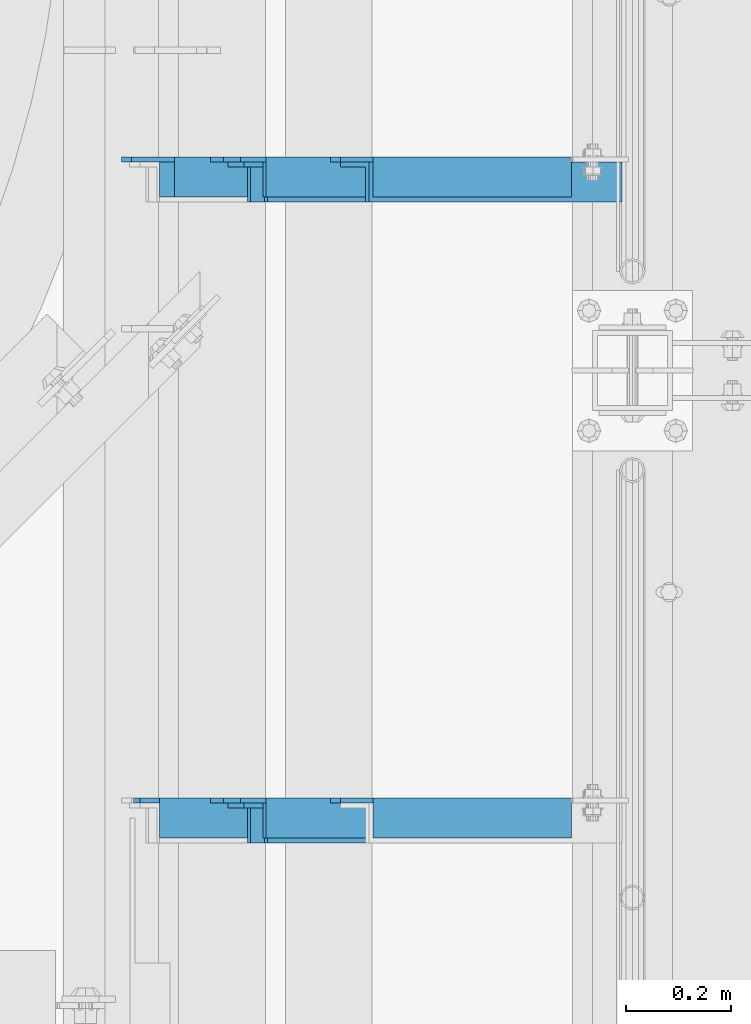
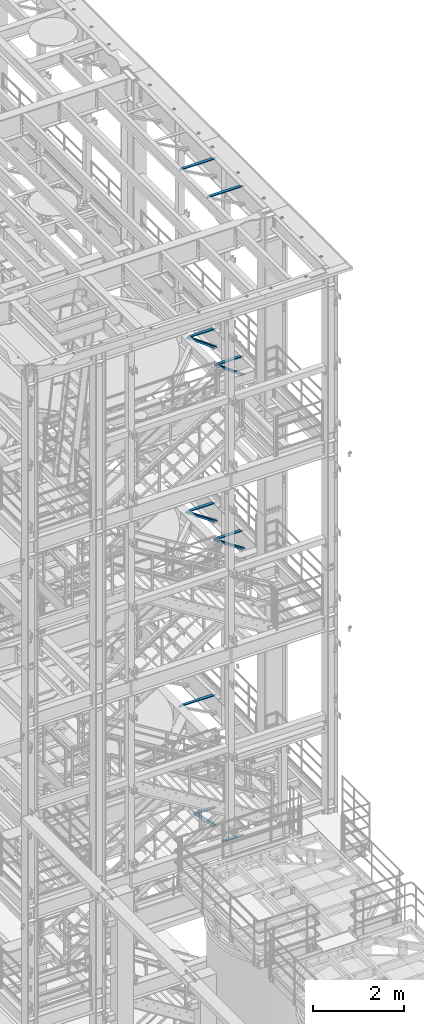
# One storey, part 1212 of 1876: 9 beams, 5 members, 14 elements without a shape of their own.
"""IFC2X3 building model written with IfcOpenShell, lengths in millimetres."""

from ifc_helpers import new_model, si_unit, frame, origin_with_axes, place, context, subcontext, project, spatial, faceted_brep, material, type_object, element, aggregate, save


model = new_model("IFC2X3")

# Units and contexts
model_context = context("Model", 3, precision=1e-05, world=origin_with_axes())
body_context = subcontext(model_context, "Body", "Model", "MODEL_VIEW")
ifc_project = project(units=[si_unit("LENGTHUNIT", "METRE", prefix="MILLI"), si_unit("AREAUNIT", "SQUARE_METRE"), si_unit("VOLUMEUNIT", "CUBIC_METRE"), si_unit("MASSUNIT", "GRAM", prefix="KILO"), si_unit("TIMEUNIT", "SECOND"), si_unit("PLANEANGLEUNIT", "RADIAN"), si_unit("SOLIDANGLEUNIT", "STERADIAN"), si_unit("THERMODYNAMICTEMPERATUREUNIT", "DEGREE_CELSIUS"), si_unit("LUMINOUSINTENSITYUNIT", "LUMEN")], contexts=[model_context])

# Site, building, storey
site_placement = place(None, origin_with_axes())
site = spatial("IfcSite", under=ifc_project, at=site_placement, CompositionType="ELEMENT")
building_placement = place(site_placement, origin_with_axes())
building = spatial("IfcBuilding", under=site, at=building_placement, Name="Undefined", CompositionType="ELEMENT")
storey_placement = place(building_placement, origin_with_axes())
storey = spatial("IfcBuildingStorey", under=building, at=storey_placement, Name="Undefined", CompositionType="ELEMENT", Elevation=0.0)

# Assembly, member
assembly_1_placement = place(storey_placement, origin_with_axes())
assembly_1 = element("IfcElementAssembly", 1, at=assembly_1_placement, inside=storey, AssemblyPlace="NOTDEFINED", PredefinedType="RIGID_FRAME")
ifc_material = material(Name="STEEL/A36")
member_type = type_object("IfcMemberType", Name="L3X3X3/8", PredefinedType="NOTDEFINED")
member_1_placement = place(assembly_1_placement, frame((7040.82073558349, -2181.225, 5132.08684596299), z_axis=(0.0, -1.0, 0.0), x_axis=(0.701378051870177, 0.0, -0.712789469868064)))
member_1 = element("IfcMember", 2, at=member_1_placement, type_object=member_type, material=ifc_material, ObjectType="L3X3X3/8", context=body_context, shape_type="Brep", body=[
    faceted_brep([(758.761261852226, 28.5750000000353, 38.0999999999999), (758.761261852226, 28.5750000000353, -28.5749999999998), (758.761261852226, -38.0999999999494, -28.5749999999998), (758.761261852226, -38.0999999999494, -38.0999999999999), (758.761261852226, 38.1000000000313, -38.0999999999999), (758.761261852226, 38.1000000000313, 38.0999999999999), (72.7035731357846, 28.5749999999971, 38.0999999999999), (72.7035731357846, 28.5749999999971, -28.5749999999998), (72.7035731357837, -38.0999999999876, -28.5749999999998), (72.7035731357837, -38.0999999999876, -38.0999999999999), (72.7035731357851, 38.0999999999949, -38.0999999999999), (72.7035731357851, 38.0999999999949, 38.0999999999999)], [[[0, 1, 2, 3, 4, 5]], [[1, 0, 6, 7]], [[2, 1, 7, 8]], [[3, 2, 8, 9]], [[4, 3, 9, 10]], [[5, 4, 10, 11]], [[0, 5, 11, 6]], [[10, 9, 8, 7, 6, 11]]]),
])
aggregate(assembly_1, [member_1])

assembly_2_placement = place(storey_placement, origin_with_axes())
assembly_2 = element("IfcElementAssembly", 3, at=assembly_2_placement, inside=storey, Name="BRACE", AssemblyPlace="NOTDEFINED", PredefinedType="RIGID_FRAME")
member_2_placement = place(assembly_2_placement, frame((6792.18717854473, -3400.425, 13303.4525776102), z_axis=(0.0, -1.0, 0.0), x_axis=(0.82801633589084, 0.0, -0.560703974926081)))
member_2 = element("IfcMember", 4, at=member_2_placement, type_object=member_type, material=ifc_material, Name="BRACE", ObjectType="L3X3X3/8", context=body_context, shape_type="Brep", body=[
    faceted_brep([(96.2629166569975, 38.0999999999149, -38.0999999999999), (96.2629166569975, 38.0999999999149, 38.0999999999999), (949.988805673232, 38.0999999993637, 38.0999999999999), (949.988805673232, 38.0999999993637, -38.0999999999999), (96.2629166570039, 28.5749999999189, 38.0999999999999), (949.98880567324, 28.5749999993659, 38.0999999999999), (96.2629166570039, 28.5749999999189, -28.5749999999998), (949.98880567324, 28.5749999993659, -28.5749999999998), (96.2629166570548, -38.1000000000404, -28.5749999999998), (949.98880567329, -38.1000000005952, -28.5749999999998), (96.2629166570548, -38.1000000000404, -38.0999999999999), (949.98880567329, -38.1000000005952, -38.0999999999999)], [[[0, 1, 2, 3]], [[1, 4, 5, 2]], [[4, 6, 7, 5]], [[6, 8, 9, 7]], [[8, 10, 11, 9]], [[10, 0, 3, 11]], [[5, 7, 9, 11, 3, 2]], [[10, 8, 6, 4, 1, 0]]]),
])
aggregate(assembly_2, [member_2])

assembly_3_placement = place(storey_placement, origin_with_axes())
assembly_3 = element("IfcElementAssembly", 5, at=assembly_3_placement, inside=storey, Name="BRACE", AssemblyPlace="NOTDEFINED", PredefinedType="RIGID_FRAME")
member_3_placement = place(assembly_3_placement, frame((6792.18717854473, -2181.225, 13303.4525776102), z_axis=(0.0, -1.0, 0.0), x_axis=(0.82801633589084, 0.0, -0.560703974926081)))
member_3 = element("IfcMember", 6, at=member_3_placement, type_object=member_type, material=ifc_material, Name="BRACE", ObjectType="L3X3X3/8", context=body_context, shape_type="Brep", body=[
    faceted_brep([(96.2629166569975, 38.0999999999149, -38.0999999999999), (96.2629166569975, 38.0999999999149, 38.0999999999999), (949.988805673232, 38.0999999993637, 38.0999999999999), (949.988805673232, 38.0999999993637, -38.0999999999999), (96.2629166570039, 28.5749999999189, 38.0999999999999), (949.98880567324, 28.5749999993659, 38.0999999999999), (96.2629166570039, 28.5749999999189, -28.5749999999998), (949.98880567324, 28.5749999993659, -28.5749999999998), (96.2629166570548, -38.1000000000404, -28.5749999999998), (949.98880567329, -38.1000000005952, -28.5749999999998), (96.2629166570548, -38.1000000000404, -38.0999999999999), (949.98880567329, -38.1000000005952, -38.0999999999999)], [[[0, 1, 2, 3]], [[1, 4, 5, 2]], [[4, 6, 7, 5]], [[6, 8, 9, 7]], [[8, 10, 11, 9]], [[10, 0, 3, 11]], [[5, 7, 9, 11, 3, 2]], [[10, 8, 6, 4, 1, 0]]]),
])
aggregate(assembly_3, [member_3])

assembly_4_placement = place(storey_placement, origin_with_axes())
assembly_4 = element("IfcElementAssembly", 7, at=assembly_4_placement, inside=storey, AssemblyPlace="NOTDEFINED", PredefinedType="RIGID_FRAME")
member_4_placement = place(assembly_4_placement, frame((6816.45156900301, -3400.425, 17993.727144592), z_axis=(0.0, -1.0, 0.0), x_axis=(0.807030325960616, 0.0, -0.590509993971229)))
member_4 = element("IfcMember", 8, at=member_4_placement, type_object=member_type, material=ifc_material, ObjectType="L3X3X3/8", context=body_context, shape_type="Brep", body=[
    faceted_brep([(107.534166499222, 38.1000000000786, -38.0999999999999), (107.534166499222, 38.1000000000786, 38.0999999999999), (943.218892448816, 38.1000000010463, 38.0999999999999), (943.218892448816, 38.1000000010463, -38.0999999999999), (107.534166499204, 28.5750000000917, 38.0999999999999), (943.2188924488, 28.5750000010594, 38.0999999999999), (107.534166499204, 28.5750000000917, -28.5749999999998), (943.2188924488, 28.5750000010594, -28.5749999999998), (107.534166499082, -38.0999999998239, -28.5749999999998), (943.218892448681, -38.0999999988562, -28.5749999999998), (107.534166499082, -38.0999999998239, -38.0999999999999), (943.218892448681, -38.0999999988562, -38.0999999999999)], [[[0, 1, 2, 3]], [[1, 4, 5, 2]], [[4, 6, 7, 5]], [[6, 8, 9, 7]], [[8, 10, 11, 9]], [[10, 0, 3, 11]], [[5, 7, 9, 11, 3, 2]], [[10, 8, 6, 4, 1, 0]]]),
])
aggregate(assembly_4, [member_4])

assembly_5_placement = place(storey_placement, origin_with_axes())
assembly_5 = element("IfcElementAssembly", 9, at=assembly_5_placement, inside=storey, AssemblyPlace="NOTDEFINED", PredefinedType="RIGID_FRAME")
member_5_placement = place(assembly_5_placement, frame((6816.45156900301, -2181.225, 17993.727144592), z_axis=(0.0, -1.0, 0.0), x_axis=(0.807030325960616, 0.0, -0.590509993971229)))
member_5 = element("IfcMember", 10, at=member_5_placement, type_object=member_type, material=ifc_material, ObjectType="L3X3X3/8", context=body_context, shape_type="Brep", body=[
    faceted_brep([(107.534166499222, 38.1000000000786, -38.0999999999999), (107.534166499222, 38.1000000000786, 38.0999999999999), (943.218892448816, 38.1000000010463, 38.0999999999999), (943.218892448816, 38.1000000010463, -38.0999999999999), (107.534166499204, 28.5750000000917, 38.0999999999999), (943.2188924488, 28.5750000010594, 38.0999999999999), (107.534166499204, 28.5750000000917, -28.5749999999998), (943.2188924488, 28.5750000010594, -28.5749999999998), (107.534166499082, -38.0999999998239, -28.5749999999998), (943.218892448681, -38.0999999988562, -28.5749999999998), (107.534166499082, -38.0999999998239, -38.0999999999999), (943.218892448681, -38.0999999988562, -38.0999999999999)], [[[0, 1, 2, 3]], [[1, 4, 5, 2]], [[4, 6, 7, 5]], [[6, 8, 9, 7]], [[8, 10, 11, 9]], [[10, 0, 3, 11]], [[5, 7, 9, 11, 3, 2]], [[10, 8, 6, 4, 1, 0]]]),
])
aggregate(assembly_5, [member_5])

# Assembly, beam
assembly_6_placement = place(storey_placement, origin_with_axes())
assembly_6 = element("IfcElementAssembly", 11, at=assembly_6_placement, inside=storey, Name="ANGLE", AssemblyPlace="NOTDEFINED", PredefinedType="RIGID_FRAME")
beam_type = type_object("IfcBeamType", Name="L3X3X3/8", PredefinedType="NOTDEFINED")
beam_1_placement = place(assembly_6_placement, frame((6642.10000000027, -2171.7, 8115.3), z_axis=(0.0, -1.0, 0.0), x_axis=(1.0, 0.0, 0.0)))
beam_1 = element("IfcBeam", 12, at=beam_1_placement, type_object=beam_type, material=ifc_material, Name="ANGLE", ObjectType="L3X3X3/8", context=body_context, shape_type="Brep", body=[
    faceted_brep([(862.013000301767, 28.5749999999998, -28.5749999999998), (862.013001168541, 28.5749999999998, 38.0999999999999), (106.361999785874, 28.5749999999998, 38.0999999999999), (106.361998852422, 28.5749999999998, -28.5749999999998), (862.013001168541, 38.1000000000004, 38.0999999999999), (106.36199978587, 38.1000000000004, 38.0999999999999), (24.6062501036349, 20.6380008697515, -28.5749999999998), (24.6062499702866, 20.6380008697515, -38.0999999999999), (5.55625073322608, 1.58800163269098, -38.0999999999999), (5.55625086657437, 1.58800163269098, -28.5749999999998), (106.361998852423, 20.6380008697515, -28.5749999999998), (106.361998719075, 20.6380008697515, -38.0999999999999), (106.361998719068, 38.1000000000004, -38.0999999999999), (862.013000177942, 38.1000000000004, -38.0999999999999), (862.013000301742, 12.6999992370602, -28.5749999999998), (862.013000177913, 12.6999992370602, -38.0999999999999), (939.006248287582, 12.6999992370602, -28.5749999999998), (939.006248163753, 12.6999992370602, -38.0999999999999), (970.756248287582, -19.0500007629398, -28.5749999999998), (970.756248163753, -19.0500007629398, -38.0999999999999), (970.75624999973, -38.1000000000004, -28.5749999999998), (970.75624999973, -38.1000000000004, -38.0999999999999), (5.55625000000055, -38.1000000000004, -28.5749999999998), (5.55625000000055, -38.1000000000004, -38.1000000000004), (5.55625073322608, -4.76199874877875, -38.0999999999999), (5.55625086657437, -4.76199874877875, -28.5749999999998)], [[[0, 1, 2, 3]], [[1, 4, 5, 2]], [[6, 7, 8, 9]], [[10, 11, 7, 6]], [[2, 5, 12, 11, 10, 3]], [[4, 13, 12, 5]], [[1, 0, 14, 15, 13, 4]], [[16, 17, 15, 14]], [[17, 16, 18, 19]], [[19, 18, 20, 21]], [[21, 20, 22, 23]], [[8, 7, 11, 12, 13, 15, 17, 19, 21, 23, 24]], [[9, 8, 24, 25]], [[20, 18, 16, 14, 0, 3, 10, 6, 9, 25, 22]], [[24, 23, 22, 25]]]),
])
aggregate(assembly_6, [beam_1])

assembly_7_placement = place(storey_placement, origin_with_axes())
assembly_7 = element("IfcElementAssembly", 13, at=assembly_7_placement, inside=storey, Name="ANGLE", AssemblyPlace="NOTDEFINED", PredefinedType="RIGID_FRAME")
beam_2_placement = place(assembly_7_placement, frame((6667.50000000095, -3390.9, 22517.1000001129), z_axis=(0.0, -1.0, 0.0), x_axis=(1.0, 0.0, 0.0)))
beam_2 = element("IfcBeam", 14, at=beam_2_placement, type_object=beam_type, material=ifc_material, Name="ANGLE", ObjectType="L3X3X3/8", context=body_context, shape_type="Brep", body=[
    faceted_brep([(836.613000301995, 28.5750000000007, -28.5749999999998), (836.613001168791, 28.5750000000007, 38.0999999999999), (52.3870335430847, 28.5750001907327, 38.0999999999858), (52.3869956588824, 28.5749999999955, -28.5750000000007), (836.613001168791, 38.0999999999985, 38.0999999999999), (52.387033543122, 38.0999999999985, 38.0999999999858), (15.8749936676099, 28.5749999999989, -28.5750000000007), (15.8749999382144, 28.5750001907327, -38.0999999999999), (3.17500012894925, 15.8750003814675, -38.0999999999999), (3.17500032897624, 15.8750003814675, -28.5749999999998), (52.3870393343063, 28.5750001907327, -38.1000000000149), (52.3869953826566, 38.0999999999954, -38.0999999999985), (836.613000178167, 38.0999999999985, -38.0999999999999), (836.613000301995, 12.6999991241828, -28.5749999999998), (836.613000178167, 12.6999991241828, -38.0999999999999), (913.60625591723, 12.6999991241828, -28.5749999999998), (913.606255793401, 12.6999991241828, -38.0999999999999), (945.35625591723, -19.0500008758172, -28.5749999999998), (945.356255793401, -19.0500008758172, -38.0999999999999), (945.356249999983, -38.0999999999985, -28.5749999999998), (945.356249999983, -38.0999999999985, -38.0999999999999), (3.17499999075153, -38.0999999999985, -28.5749999999998), (3.17499999075153, -38.0999999999985, -38.0999999999999), (3.17500012894925, 3.17500152587672, -38.0999999999999), (3.17500032897624, 3.17500152587672, -28.5749999999998)], [[[0, 1, 2, 3]], [[1, 4, 5, 2]], [[6, 7, 8, 9]], [[3, 10, 7, 6]], [[2, 5, 11, 10, 3]], [[4, 12, 11, 5]], [[1, 0, 13, 14, 12, 4]], [[15, 16, 14, 13]], [[16, 15, 17, 18]], [[18, 17, 19, 20]], [[20, 19, 21, 22]], [[8, 7, 10, 11, 12, 14, 16, 18, 20, 22, 23]], [[9, 8, 23, 24]], [[19, 17, 15, 13, 0, 3, 6, 9, 24, 21]], [[23, 22, 21, 24]]]),
])
aggregate(assembly_7, [beam_2])

assembly_8_placement = place(storey_placement, origin_with_axes())
assembly_8 = element("IfcElementAssembly", 15, at=assembly_8_placement, inside=storey, Name="ANGLE", AssemblyPlace="NOTDEFINED", PredefinedType="RIGID_FRAME")
beam_3_placement = place(assembly_8_placement, frame((6667.50000000095, -2171.7, 22517.1000001129), z_axis=(0.0, -1.0, 0.0), x_axis=(1.0, 0.0, 0.0)))
beam_3 = element("IfcBeam", 16, at=beam_3_placement, type_object=beam_type, material=ifc_material, Name="ANGLE", ObjectType="L3X3X3/8", context=body_context, shape_type="Brep", body=[
    faceted_brep([(836.613000301995, 28.5750000000007, -28.5749999999998), (836.613001168791, 28.5750000000007, 38.0999999999999), (52.3870335430847, 28.5750001907327, 38.0999999999858), (52.3869956588824, 28.5749999999955, -28.5750000000007), (836.613001168791, 38.0999999999985, 38.0999999999999), (52.387033543122, 38.0999999999985, 38.0999999999858), (15.8749936676099, 28.5749999999989, -28.5750000000007), (15.8749999382144, 28.5750001907327, -38.0999999999999), (3.17500012894925, 15.8750003814675, -38.0999999999999), (3.17500032897624, 15.8750003814675, -28.5749999999998), (52.3870393343063, 28.5750001907327, -38.1000000000149), (52.3869953826566, 38.0999999999954, -38.0999999999985), (836.613000178167, 38.0999999999985, -38.0999999999999), (836.613000301995, 12.6999991241828, -28.5749999999998), (836.613000178167, 12.6999991241828, -38.0999999999999), (913.60625591723, 12.6999991241828, -28.5749999999998), (913.606255793401, 12.6999991241828, -38.0999999999999), (945.35625591723, -19.0500008758172, -28.5749999999998), (945.356255793401, -19.0500008758172, -38.0999999999999), (945.356249999983, -38.0999999999985, -28.5749999999998), (945.356249999983, -38.0999999999985, -38.0999999999999), (3.17499999075153, -38.0999999999985, -28.5749999999998), (3.17499999075153, -38.0999999999985, -38.0999999999999), (3.17500012894925, 3.17500152587672, -38.0999999999999), (3.17500032897624, 3.17500152587672, -28.5749999999998)], [[[0, 1, 2, 3]], [[1, 4, 5, 2]], [[6, 7, 8, 9]], [[3, 10, 7, 6]], [[2, 5, 11, 10, 3]], [[4, 12, 11, 5]], [[1, 0, 13, 14, 12, 4]], [[15, 16, 14, 13]], [[16, 15, 17, 18]], [[18, 17, 19, 20]], [[20, 19, 21, 22]], [[8, 7, 10, 11, 12, 14, 16, 18, 20, 22, 23]], [[9, 8, 23, 24]], [[19, 17, 15, 13, 0, 3, 6, 9, 24, 21]], [[23, 22, 21, 24]]]),
])
aggregate(assembly_8, [beam_3])

assembly_9_placement = place(storey_placement, origin_with_axes())
assembly_9 = element("IfcElementAssembly", 17, at=assembly_9_placement, inside=storey, Name="ANGLE", AssemblyPlace="NOTDEFINED", PredefinedType="RIGID_FRAME")
beam_4_placement = place(assembly_9_placement, frame((6838.94981327725, -3390.9, 17945.1), z_axis=(0.0, -1.0, 0.0), x_axis=(1.0, 0.0, 0.0)))
beam_4 = element("IfcBeam", 18, at=beam_4_placement, type_object=beam_type, material=ifc_material, Name="ANGLE", ObjectType="L3X3X3/8", context=body_context, shape_type="Brep", body=[
    faceted_brep([(665.163187024773, 28.5750000000007, -28.5749999999998), (665.163187891547, 28.5750000000007, 38.0999999999999), (84.137014014791, 28.5749999999998, 38.1000000000258), (84.1370001605219, 28.5749999999998, -28.5750000000007), (665.163187891547, 38.0999999999985, 38.0999999999999), (84.136999759924, 38.0999999999985, 38.0999999999999), (84.1369986264499, 22.2250007629373, -28.5749999999998), (84.1369984645216, 22.2250007629373, -38.0999999999999), (34.9250004786818, 22.2250007629373, -38.0999999999999), (34.9250006406101, 22.2250007629373, -28.5749999999998), (84.1369984645207, 38.0999999999985, -38.0999999999999), (665.163186900948, 38.0999999999985, -38.0999999999999), (665.163187024748, 12.6999992370475, -28.5749999999998), (665.16318690092, 12.6999992370475, -38.0999999999999), (742.156442639983, 12.6999992370475, -28.5749999999998), (742.156442516154, 12.6999992370475, -38.0999999999999), (773.906442639983, -19.0500007629525, -28.5749999999998), (773.906442516154, -19.0500007629525, -38.0999999999999), (773.906436722751, -38.0999999999985, -28.5749999999998), (773.906436722751, -38.0999999999985, -38.0999999999999), (3.17499999075153, -38.0999999999985, -28.5749999999998), (3.17499999075153, -38.0999999999985, -38.0999999999999), (3.1750004786818, -9.52499923706273, -38.0999999999999), (3.17500064061005, -9.52499923706273, -28.5749999999998)], [[[0, 1, 2, 3]], [[1, 4, 5, 2]], [[6, 7, 8, 9]], [[2, 5, 10, 7, 6, 3]], [[4, 11, 10, 5]], [[1, 0, 12, 13, 11, 4]], [[14, 15, 13, 12]], [[15, 14, 16, 17]], [[17, 16, 18, 19]], [[19, 18, 20, 21]], [[8, 7, 10, 11, 13, 15, 17, 19, 21, 22]], [[9, 8, 22, 23]], [[18, 16, 14, 12, 0, 3, 6, 9, 23, 20]], [[22, 21, 20, 23]]]),
])
aggregate(assembly_9, [beam_4])

assembly_10_placement = place(storey_placement, origin_with_axes())
assembly_10 = element("IfcElementAssembly", 19, at=assembly_10_placement, inside=storey, Name="ANGLE", AssemblyPlace="NOTDEFINED", PredefinedType="RIGID_FRAME")
beam_5_placement = place(assembly_10_placement, frame((6838.94981327725, -2171.7, 17945.1), z_axis=(0.0, -1.0, 0.0), x_axis=(1.0, 0.0, 0.0)))
beam_5 = element("IfcBeam", 20, at=beam_5_placement, type_object=beam_type, material=ifc_material, Name="ANGLE", ObjectType="L3X3X3/8", context=body_context, shape_type="Brep", body=[
    faceted_brep([(665.163187024773, 28.5750000000007, -28.5749999999998), (665.163187891547, 28.5750000000007, 38.0999999999999), (84.137014014791, 28.5749999999998, 38.1000000000258), (84.1370001605219, 28.5749999999998, -28.5750000000007), (665.163187891547, 38.0999999999985, 38.0999999999999), (84.136999759924, 38.0999999999985, 38.0999999999999), (84.1369986264499, 22.2250007629373, -28.5749999999998), (84.1369984645216, 22.2250007629373, -38.0999999999999), (34.9250004786818, 22.2250007629373, -38.0999999999999), (34.9250006406101, 22.2250007629373, -28.5749999999998), (84.1369984645207, 38.0999999999985, -38.0999999999999), (665.163186900948, 38.0999999999985, -38.0999999999999), (665.163187024748, 12.6999992370475, -28.5749999999998), (665.16318690092, 12.6999992370475, -38.0999999999999), (742.156442639983, 12.6999992370475, -28.5749999999998), (742.156442516154, 12.6999992370475, -38.0999999999999), (773.906442639983, -19.0500007629525, -28.5749999999998), (773.906442516154, -19.0500007629525, -38.0999999999999), (773.906436722751, -38.0999999999985, -28.5749999999998), (773.906436722751, -38.0999999999985, -38.0999999999999), (3.17499999075153, -38.0999999999985, -28.5749999999998), (3.17499999075153, -38.0999999999985, -38.0999999999999), (3.1750004786818, -9.52499923706273, -38.0999999999999), (3.17500064061005, -9.52499923706273, -28.5749999999998)], [[[0, 1, 2, 3]], [[1, 4, 5, 2]], [[6, 7, 8, 9]], [[2, 5, 10, 7, 6, 3]], [[4, 11, 10, 5]], [[1, 0, 12, 13, 11, 4]], [[14, 15, 13, 12]], [[15, 14, 16, 17]], [[17, 16, 18, 19]], [[19, 18, 20, 21]], [[8, 7, 10, 11, 13, 15, 17, 19, 21, 22]], [[9, 8, 22, 23]], [[18, 16, 14, 12, 0, 3, 6, 9, 23, 20]], [[22, 21, 20, 23]]]),
])
aggregate(assembly_10, [beam_5])

assembly_11_placement = place(storey_placement, origin_with_axes())
assembly_11 = element("IfcElementAssembly", 21, at=assembly_11_placement, inside=storey, Name="ANGLE", AssemblyPlace="NOTDEFINED", PredefinedType="RIGID_FRAME")
beam_6_placement = place(assembly_11_placement, frame((7042.15, -3390.9, 5092.7), z_axis=(0.0, -1.0, 0.0), x_axis=(1.0, 0.0, 0.0)))
beam_6 = element("IfcBeam", 22, at=beam_6_placement, type_object=beam_type, material=ifc_material, Name="ANGLE", ObjectType="L3X3X3/8", context=body_context, shape_type="Brep", body=[
    faceted_brep([(461.963000256203, 28.5750000000007, -28.5749999999998), (461.963001056292, 28.5750000000007, 38.0999999999999), (84.1370686928021, 28.5750001907327, 38.100000000024), (84.1370606917826, 28.5750000000007, -28.5749999999771), (461.963001056292, 38.1000000000004, 38.0999999999999), (84.1374011325761, 38.0999999999985, 38.0999999999776), (22.2249552881549, 26.9870083863452, -28.5749999999935), (22.2249551643299, 26.9870094055232, -38.0999999999931), (3.17495592726937, 7.93701016846171, -38.0999999999995), (3.17495605109434, 7.93700914928468, -28.5749999999989), (84.1369575769495, 26.9870083863452, -28.5749999999744), (84.1369574531245, 26.9870094055223, -38.099999999974), (84.137408980816, 38.0999999999985, -38.1000000000231), (461.963000141903, 38.1000000000004, -38.0999999999999), (461.963000302011, 12.6999992370611, -28.5749999999998), (461.963000178182, 12.6999992370611, -38.0999999999999), (538.956248287851, 12.6999992370611, -28.5749999999998), (538.956248164022, 12.6999992370611, -38.0999999999999), (570.706248287851, -19.0500007629389, -28.5749999999998), (570.706248164022, -19.0500007629389, -38.0999999999999), (570.706249999999, -38.1000000000004, -28.5749999999998), (570.706249999999, -38.1000000000004, -38.0999999999999), (3.17499999075153, -38.0999999999985, -28.5749999999998), (3.17499999075153, -38.0999999999985, -38.0999999999999), (3.17495592726937, 1.58700978699198, -38.0999999999995), (3.17495605109434, 1.58700876781495, -28.5749999999989)], [[[0, 1, 2, 3]], [[1, 4, 5, 2]], [[6, 7, 8, 9]], [[10, 11, 7, 6]], [[2, 5, 12, 11, 10, 3]], [[4, 13, 12, 5]], [[1, 0, 14, 15, 13, 4]], [[16, 17, 15, 14]], [[17, 16, 18, 19]], [[19, 18, 20, 21]], [[21, 20, 22, 23]], [[8, 7, 11, 12, 13, 15, 17, 19, 21, 23, 24]], [[9, 8, 24, 25]], [[20, 18, 16, 14, 0, 3, 10, 6, 9, 25, 22]], [[24, 23, 22, 25]]]),
])
aggregate(assembly_11, [beam_6])

assembly_12_placement = place(storey_placement, origin_with_axes())
assembly_12 = element("IfcElementAssembly", 23, at=assembly_12_placement, inside=storey, Name="ANGLE", AssemblyPlace="NOTDEFINED", PredefinedType="RIGID_FRAME")
beam_7_placement = place(assembly_12_placement, frame((7042.15, -2171.7, 5092.7), z_axis=(0.0, -1.0, 0.0), x_axis=(1.0, 0.0, 0.0)))
beam_7 = element("IfcBeam", 24, at=beam_7_placement, type_object=beam_type, material=ifc_material, Name="ANGLE", ObjectType="L3X3X3/8", context=body_context, shape_type="Brep", body=[
    faceted_brep([(461.963000256203, 28.5750000000007, -28.5749999999998), (461.963001056292, 28.5750000000007, 38.0999999999999), (84.1370686928021, 28.5750001907327, 38.100000000024), (84.1370606917826, 28.5750000000007, -28.5749999999771), (461.963001056292, 38.1000000000004, 38.0999999999999), (84.1374011325761, 38.0999999999985, 38.0999999999776), (22.2249552881549, 26.9870083863452, -28.5749999999935), (22.2249551643299, 26.9870094055232, -38.0999999999931), (3.17495592726937, 7.93701016846171, -38.0999999999995), (3.17495605109434, 7.93700914928468, -28.5749999999989), (84.1369575769495, 26.9870083863452, -28.5749999999744), (84.1369574531245, 26.9870094055223, -38.099999999974), (84.137408980816, 38.0999999999985, -38.1000000000231), (461.963000141903, 38.1000000000004, -38.0999999999999), (461.963000302011, 12.6999992370611, -28.5749999999998), (461.963000178182, 12.6999992370611, -38.0999999999999), (538.956248287851, 12.6999992370611, -28.5749999999998), (538.956248164022, 12.6999992370611, -38.0999999999999), (570.706248287851, -19.0500007629389, -28.5749999999998), (570.706248164022, -19.0500007629389, -38.0999999999999), (570.706249999999, -38.1000000000004, -28.5749999999998), (570.706249999999, -38.1000000000004, -38.0999999999999), (3.17499999075153, -38.0999999999985, -28.5749999999998), (3.17499999075153, -38.0999999999985, -38.0999999999999), (3.17495592726937, 1.58700978699198, -38.0999999999995), (3.17495605109434, 1.58700876781495, -28.5749999999989)], [[[0, 1, 2, 3]], [[1, 4, 5, 2]], [[6, 7, 8, 9]], [[10, 11, 7, 6]], [[2, 5, 12, 11, 10, 3]], [[4, 13, 12, 5]], [[1, 0, 14, 15, 13, 4]], [[16, 17, 15, 14]], [[17, 16, 18, 19]], [[19, 18, 20, 21]], [[21, 20, 22, 23]], [[8, 7, 11, 12, 13, 15, 17, 19, 21, 23, 24]], [[9, 8, 24, 25]], [[20, 18, 16, 14, 0, 3, 10, 6, 9, 25, 22]], [[24, 23, 22, 25]]]),
])
aggregate(assembly_12, [beam_7])

assembly_13_placement = place(storey_placement, origin_with_axes())
assembly_13 = element("IfcElementAssembly", 25, at=assembly_13_placement, inside=storey, Name="ANGLE", AssemblyPlace="NOTDEFINED", PredefinedType="RIGID_FRAME")
beam_8_placement = place(assembly_13_placement, frame((6813.54999999292, -3390.9, 13271.4999999928), z_axis=(0.0, -1.0, 0.0), x_axis=(1.0, 0.0, 0.0)))
beam_8 = element("IfcBeam", 26, at=beam_8_placement, type_object=beam_type, material=ifc_material, Name="ANGLE", ObjectType="L3X3X3/8", context=body_context, shape_type="Brep", body=[
    faceted_brep([(690.56300030954, 28.5750000000007, -28.5749999999998), (690.563001176313, 28.5750000000007, 38.0999999999999), (103.186999799132, 28.5750000000007, 38.0999999999999), (103.186998865692, 28.5750000000007, -28.5749999999998), (690.563001175733, 38.1000000000004, 38.0999999999999), (103.186999799132, 38.1000000000004, 38.0999999999999), (103.186998865692, 22.2250007629391, -28.5749999999998), (103.186998732343, 22.2250007629391, -38.0999999999999), (29.3687518909128, 22.2250007629391, -38.0999999999999), (29.3687520242611, 22.2250007629391, -28.5749999999998), (103.186998732343, 38.1000000000004, -38.0999999999999), (690.563000185135, 38.1000000000004, -38.0999999999999), (690.563000310482, 12.6999992442816, -28.5749999999998), (690.563000186654, 12.6999992442816, -38.0999999999999), (767.556248294582, 12.6999992442816, -28.5749999999998), (767.556248170753, 12.6999992442816, -38.0999999999999), (799.306248294582, -19.0500007557184, -28.5749999999998), (799.306248170753, -19.0500007557184, -38.0999999999999), (799.30625000673, -38.1000000000004, -28.5749999999998), (799.30625000673, -38.1000000000004, -38.0999999999999), (3.96875000000273, -38.1000000000004, -28.5749999999998), (3.96875000000273, -38.1000000000004, -38.0999999999999), (3.96875227238252, -3.17500076293982, -38.0999999999999), (3.96875240573081, -3.17500076293982, -28.5749999999998)], [[[0, 1, 2, 3]], [[1, 4, 5, 2]], [[6, 7, 8, 9]], [[2, 5, 10, 7, 6, 3]], [[4, 11, 10, 5]], [[1, 0, 12, 13, 11, 4]], [[14, 15, 13, 12]], [[15, 14, 16, 17]], [[17, 16, 18, 19]], [[19, 18, 20, 21]], [[8, 7, 10, 11, 13, 15, 17, 19, 21, 22]], [[9, 8, 22, 23]], [[18, 16, 14, 12, 0, 3, 6, 9, 23, 20]], [[22, 21, 20, 23]]]),
])
aggregate(assembly_13, [beam_8])

assembly_14_placement = place(storey_placement, origin_with_axes())
assembly_14 = element("IfcElementAssembly", 27, at=assembly_14_placement, inside=storey, Name="ANGLE", AssemblyPlace="NOTDEFINED", PredefinedType="RIGID_FRAME")
beam_9_placement = place(assembly_14_placement, frame((6813.54999999292, -2171.7, 13271.4999999928), z_axis=(0.0, -1.0, 0.0), x_axis=(1.0, 0.0, 0.0)))
beam_9 = element("IfcBeam", 28, at=beam_9_placement, type_object=beam_type, material=ifc_material, Name="ANGLE", ObjectType="L3X3X3/8", context=body_context, shape_type="Brep", body=[
    faceted_brep([(690.56300030954, 28.5750000000007, -28.5749999999998), (690.563001176313, 28.5750000000007, 38.0999999999999), (103.186999799132, 28.5750000000007, 38.0999999999999), (103.186998865692, 28.5750000000007, -28.5749999999998), (690.563001175733, 38.1000000000004, 38.0999999999999), (103.186999799132, 38.1000000000004, 38.0999999999999), (103.186998865692, 22.2250007629391, -28.5749999999998), (103.186998732343, 22.2250007629391, -38.0999999999999), (29.3687518909128, 22.2250007629391, -38.0999999999999), (29.3687520242611, 22.2250007629391, -28.5749999999998), (103.186998732343, 38.1000000000004, -38.0999999999999), (690.563000185135, 38.1000000000004, -38.0999999999999), (690.563000310482, 12.6999992442816, -28.5749999999998), (690.563000186654, 12.6999992442816, -38.0999999999999), (767.556248294582, 12.6999992442816, -28.5749999999998), (767.556248170753, 12.6999992442816, -38.0999999999999), (799.306248294582, -19.0500007557184, -28.5749999999998), (799.306248170753, -19.0500007557184, -38.0999999999999), (799.30625000673, -38.1000000000004, -28.5749999999998), (799.30625000673, -38.1000000000004, -38.0999999999999), (3.96875000000273, -38.1000000000004, -28.5749999999998), (3.96875000000273, -38.1000000000004, -38.0999999999999), (3.96875227238252, -3.17500076293982, -38.0999999999999), (3.96875240573081, -3.17500076293982, -28.5749999999998)], [[[0, 1, 2, 3]], [[1, 4, 5, 2]], [[6, 7, 8, 9]], [[2, 5, 10, 7, 6, 3]], [[4, 11, 10, 5]], [[1, 0, 12, 13, 11, 4]], [[14, 15, 13, 12]], [[15, 14, 16, 17]], [[17, 16, 18, 19]], [[19, 18, 20, 21]], [[8, 7, 10, 11, 13, 15, 17, 19, 21, 22]], [[9, 8, 22, 23]], [[18, 16, 14, 12, 0, 3, 6, 9, 23, 20]], [[22, 21, 20, 23]]]),
])
aggregate(assembly_14, [beam_9])

save(model, "model.ifc")
